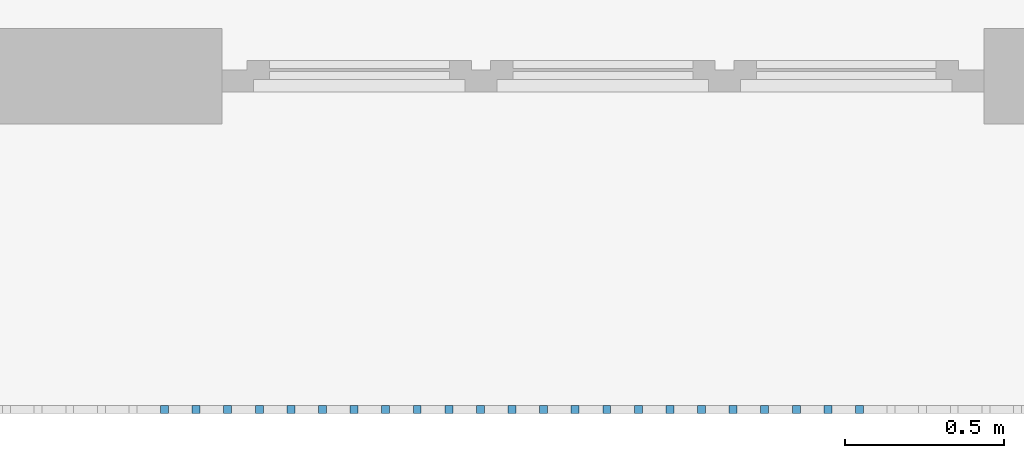
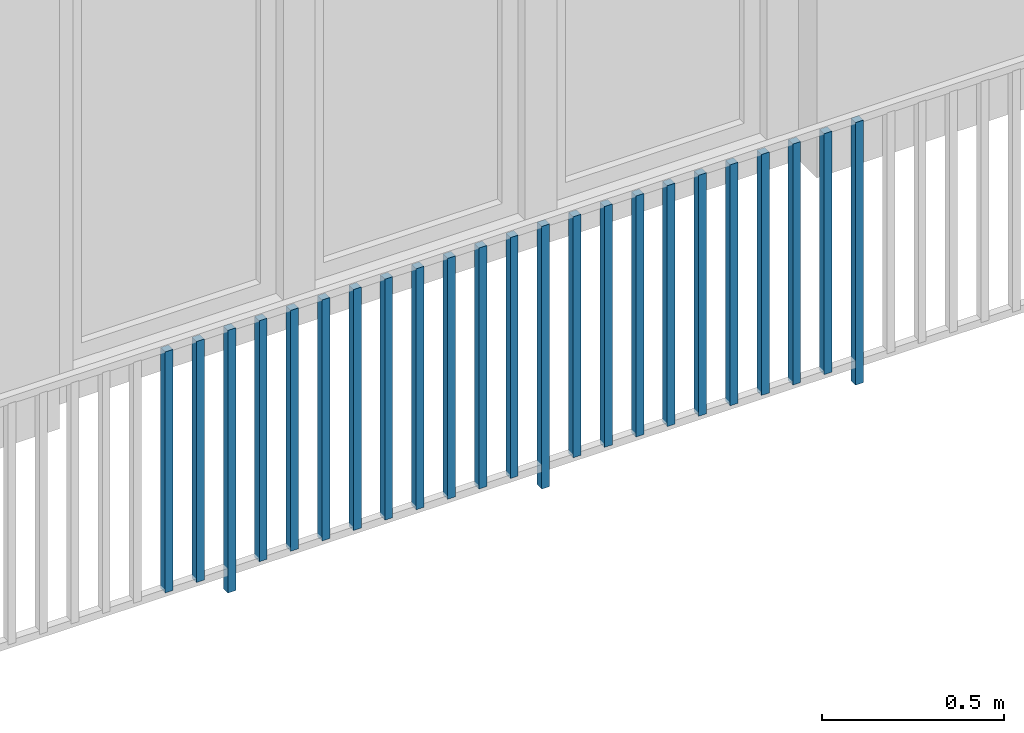
# One storey, part 34 of 54: 23 building element parts, 1 element without a shape of its own.
"""IFC4 building model written with IfcOpenShell, lengths in metres."""

from ifc_helpers import new_model, entity, si_unit, converted_unit, derived_unit, direction, frame, origin_with_axes, place, context, subcontext, project, spatial, polygons, material, type_object, element, aggregate, save


model = new_model("IFC4")

# Units and contexts
model_context = context("Model", 3, precision=1e-05, world=origin_with_axes(), true_north=direction((0.0, 1.0)))
body_context = subcontext(model_context, "Body", "Model", "MODEL_VIEW")
ifc_project = project(units=[si_unit("LENGTHUNIT", "METRE"), si_unit("AREAUNIT", "SQUARE_METRE"), si_unit("VOLUMEUNIT", "CUBIC_METRE"), converted_unit("PLANEANGLEUNIT", "DEGREE", entity("IfcPlaneAngleMeasure", 0.0174532925199), si_unit("PLANEANGLEUNIT", "RADIAN"), dimensions=[0, 0, 0, 0, 0, 0, 0]), converted_unit("TIMEUNIT", "Year", entity("IfcTimeMeasure", 31556926.0), si_unit("TIMEUNIT", "SECOND"), dimensions=[0, 0, 1, 0, 0, 0, 0]), si_unit("MASSUNIT", "GRAM", prefix="KILO"), si_unit("THERMODYNAMICTEMPERATUREUNIT", "DEGREE_CELSIUS"), si_unit("LUMINOUSINTENSITYUNIT", "LUMEN"), si_unit("ENERGYUNIT", "JOULE", prefix="MEGA"), derived_unit("THERMALCONDUCTANCEUNIT", [(si_unit("POWERUNIT", "WATT"), 1), (si_unit("LENGTHUNIT", "METRE"), -1), (si_unit("THERMODYNAMICTEMPERATUREUNIT", "KELVIN"), -1)]), derived_unit("SPECIFICHEATCAPACITYUNIT", [(si_unit("ENERGYUNIT", "JOULE"), 1), (si_unit("MASSUNIT", "GRAM", prefix="KILO"), -1), (si_unit("THERMODYNAMICTEMPERATUREUNIT", "KELVIN"), -1)]), derived_unit("MASSDENSITYUNIT", [(si_unit("MASSUNIT", "GRAM", prefix="KILO"), 1), (si_unit("VOLUMEUNIT", "CUBIC_METRE"), -1)])], contexts=[model_context])

# Site, building, storey, space
site_placement = place(None, origin_with_axes())
site = spatial("IfcSite", under=ifc_project, at=site_placement, CompositionType="ELEMENT")
building_placement = place(site_placement, origin_with_axes())
building = spatial("IfcBuilding", under=site, at=building_placement, CompositionType="ELEMENT")
storey_placement = place(building_placement, frame((0.0, 0.0, 9.18), z_axis=(0.0, 0.0, 1.0), x_axis=(1.0, 0.0, 0.0)))
storey = spatial("IfcBuildingStorey", under=building, at=storey_placement, Name="3. Geschoss", CompositionType="ELEMENT", Elevation=9.18)
space_placement = place(storey_placement, frame((10.2378006196, 9.82118769833, 0.0), z_axis=(0.0, 0.0, 1.0), x_axis=(-1.0, 0.0, 0.0)))
space = spatial("IfcSpace", under=storey, at=space_placement, CompositionType="ELEMENT", PredefinedType="EXTERNAL")

# Railing, building element parts
railing_type = type_object("IfcRailingType", PredefinedType="NOTDEFINED")
railing_placement = place(space_placement, frame((0.0, -7.06315681498e-08, 0.0), z_axis=(0.0, 0.0, 1.0), x_axis=(-1.0, 0.0, 0.0)))
railing = element("IfcRailing", 1, at=railing_placement, inside=space, type_object=railing_type, PredefinedType="NOTDEFINED")
ifc_material = material()
building_element_part_1_placement = place(railing_placement, origin_with_axes())
building_element_part_1 = element("IfcBuildingElementPart", 2, at=building_element_part_1_placement, material=ifc_material, PredefinedType="NOTDEFINED", context=body_context, shape_type="Tessellation", body=[
    polygons([(-17.0977608696, -20.6625, 0.07), (-17.0977608696, -20.6375, 0.07), (-17.0977608696, -20.6375, 0.8775), (-17.0977608696, -20.6625, 0.8775), (-17.1227608696, -20.6625, 0.07), (-17.1227608696, -20.6375, 0.07), (-17.1227608696, -20.6375, 0.8775), (-17.1227608696, -20.6625, 0.8775)], [[[1, 2, 3, 4]], [[1, 5, 6, 2]], [[2, 6, 7, 3]], [[4, 3, 7, 8]], [[5, 1, 4, 8]], [[6, 5, 8, 7]]], closed=True),
])
building_element_part_2_placement = place(railing_placement, origin_with_axes())
building_element_part_2 = element("IfcBuildingElementPart", 3, at=building_element_part_2_placement, material=ifc_material, PredefinedType="NOTDEFINED", context=body_context, shape_type="Tessellation", body=[
    polygons([(-16.9982826087, -20.6625, 0.07), (-16.9982826087, -20.6375, 0.07), (-16.9982826087, -20.6375, 0.8775), (-16.9982826087, -20.6625, 0.8775), (-17.0232826087, -20.6625, 0.07), (-17.0232826087, -20.6375, 0.07), (-17.0232826087, -20.6375, 0.8775), (-17.0232826087, -20.6625, 0.8775)], [[[1, 2, 3, 4]], [[1, 5, 6, 2]], [[2, 6, 7, 3]], [[4, 3, 7, 8]], [[5, 1, 4, 8]], [[6, 5, 8, 7]]], closed=True),
])
building_element_part_3_placement = place(railing_placement, origin_with_axes())
building_element_part_3 = element("IfcBuildingElementPart", 4, at=building_element_part_3_placement, material=ifc_material, PredefinedType="NOTDEFINED", context=body_context, shape_type="Tessellation", body=[
    polygons([(-16.8988043478, -20.6625, 0.0), (-16.8988043478, -20.6375, 0.0), (-16.8988043478, -20.6375, 0.88), (-16.8988043478, -20.6625, 0.88), (-16.9238043478, -20.6625, 0.0), (-16.9238043478, -20.6375, 0.0), (-16.9238043478, -20.6375, 0.88), (-16.9238043478, -20.6625, 0.88)], [[[1, 2, 3, 4]], [[1, 5, 6, 2]], [[2, 6, 7, 3]], [[4, 3, 7, 8]], [[5, 1, 4, 8]], [[6, 5, 8, 7]]], closed=True),
])
building_element_part_4_placement = place(railing_placement, origin_with_axes())
building_element_part_4 = element("IfcBuildingElementPart", 5, at=building_element_part_4_placement, material=ifc_material, PredefinedType="NOTDEFINED", context=body_context, shape_type="Tessellation", body=[
    polygons([(-16.799326087, -20.6625, 0.07), (-16.799326087, -20.6375, 0.07), (-16.799326087, -20.6375, 0.8775), (-16.799326087, -20.6625, 0.8775), (-16.824326087, -20.6625, 0.07), (-16.824326087, -20.6375, 0.07), (-16.824326087, -20.6375, 0.8775), (-16.824326087, -20.6625, 0.8775)], [[[1, 2, 3, 4]], [[1, 5, 6, 2]], [[2, 6, 7, 3]], [[4, 3, 7, 8]], [[5, 1, 4, 8]], [[6, 5, 8, 7]]], closed=True),
])
building_element_part_5_placement = place(railing_placement, origin_with_axes())
building_element_part_5 = element("IfcBuildingElementPart", 6, at=building_element_part_5_placement, material=ifc_material, PredefinedType="NOTDEFINED", context=body_context, shape_type="Tessellation", body=[
    polygons([(-16.6998478261, -20.6625, 0.07), (-16.6998478261, -20.6375, 0.07), (-16.6998478261, -20.6375, 0.8775), (-16.6998478261, -20.6625, 0.8775), (-16.7248478261, -20.6625, 0.07), (-16.7248478261, -20.6375, 0.07), (-16.7248478261, -20.6375, 0.8775), (-16.7248478261, -20.6625, 0.8775)], [[[1, 2, 3, 4]], [[1, 5, 6, 2]], [[2, 6, 7, 3]], [[4, 3, 7, 8]], [[5, 1, 4, 8]], [[6, 5, 8, 7]]], closed=True),
])
building_element_part_6_placement = place(railing_placement, origin_with_axes())
building_element_part_6 = element("IfcBuildingElementPart", 7, at=building_element_part_6_placement, material=ifc_material, PredefinedType="NOTDEFINED", context=body_context, shape_type="Tessellation", body=[
    polygons([(-16.6003695652, -20.6625, 0.07), (-16.6003695652, -20.6375, 0.07), (-16.6003695652, -20.6375, 0.8775), (-16.6003695652, -20.6625, 0.8775), (-16.6253695652, -20.6625, 0.07), (-16.6253695652, -20.6375, 0.07), (-16.6253695652, -20.6375, 0.8775), (-16.6253695652, -20.6625, 0.8775)], [[[1, 2, 3, 4]], [[1, 5, 6, 2]], [[2, 6, 7, 3]], [[4, 3, 7, 8]], [[5, 1, 4, 8]], [[6, 5, 8, 7]]], closed=True),
])
building_element_part_7_placement = place(railing_placement, origin_with_axes())
building_element_part_7 = element("IfcBuildingElementPart", 8, at=building_element_part_7_placement, material=ifc_material, PredefinedType="NOTDEFINED", context=body_context, shape_type="Tessellation", body=[
    polygons([(-16.5008913043, -20.6625, 0.07), (-16.5008913043, -20.6375, 0.07), (-16.5008913043, -20.6375, 0.8775), (-16.5008913043, -20.6625, 0.8775), (-16.5258913043, -20.6625, 0.07), (-16.5258913043, -20.6375, 0.07), (-16.5258913043, -20.6375, 0.8775), (-16.5258913043, -20.6625, 0.8775)], [[[1, 2, 3, 4]], [[1, 5, 6, 2]], [[2, 6, 7, 3]], [[4, 3, 7, 8]], [[5, 1, 4, 8]], [[6, 5, 8, 7]]], closed=True),
])
building_element_part_8_placement = place(railing_placement, origin_with_axes())
building_element_part_8 = element("IfcBuildingElementPart", 9, at=building_element_part_8_placement, material=ifc_material, PredefinedType="NOTDEFINED", context=body_context, shape_type="Tessellation", body=[
    polygons([(-16.4014130435, -20.6625, 0.07), (-16.4014130435, -20.6375, 0.07), (-16.4014130435, -20.6375, 0.8775), (-16.4014130435, -20.6625, 0.8775), (-16.4264130435, -20.6625, 0.07), (-16.4264130435, -20.6375, 0.07), (-16.4264130435, -20.6375, 0.8775), (-16.4264130435, -20.6625, 0.8775)], [[[1, 2, 3, 4]], [[1, 5, 6, 2]], [[2, 6, 7, 3]], [[4, 3, 7, 8]], [[5, 1, 4, 8]], [[6, 5, 8, 7]]], closed=True),
])
building_element_part_9_placement = place(railing_placement, origin_with_axes())
building_element_part_9 = element("IfcBuildingElementPart", 10, at=building_element_part_9_placement, material=ifc_material, PredefinedType="NOTDEFINED", context=body_context, shape_type="Tessellation", body=[
    polygons([(-16.3019347826, -20.6625, 0.07), (-16.3019347826, -20.6375, 0.07), (-16.3019347826, -20.6375, 0.8775), (-16.3019347826, -20.6625, 0.8775), (-16.3269347826, -20.6625, 0.07), (-16.3269347826, -20.6375, 0.07), (-16.3269347826, -20.6375, 0.8775), (-16.3269347826, -20.6625, 0.8775)], [[[1, 2, 3, 4]], [[1, 5, 6, 2]], [[2, 6, 7, 3]], [[4, 3, 7, 8]], [[5, 1, 4, 8]], [[6, 5, 8, 7]]], closed=True),
])
building_element_part_10_placement = place(railing_placement, origin_with_axes())
building_element_part_10 = element("IfcBuildingElementPart", 11, at=building_element_part_10_placement, material=ifc_material, PredefinedType="NOTDEFINED", context=body_context, shape_type="Tessellation", body=[
    polygons([(-16.2024565217, -20.6625, 0.07), (-16.2024565217, -20.6375, 0.07), (-16.2024565217, -20.6375, 0.8775), (-16.2024565217, -20.6625, 0.8775), (-16.2274565217, -20.6625, 0.07), (-16.2274565217, -20.6375, 0.07), (-16.2274565217, -20.6375, 0.8775), (-16.2274565217, -20.6625, 0.8775)], [[[1, 2, 3, 4]], [[1, 5, 6, 2]], [[2, 6, 7, 3]], [[4, 3, 7, 8]], [[5, 1, 4, 8]], [[6, 5, 8, 7]]], closed=True),
])
building_element_part_11_placement = place(railing_placement, origin_with_axes())
building_element_part_11 = element("IfcBuildingElementPart", 12, at=building_element_part_11_placement, material=ifc_material, PredefinedType="NOTDEFINED", context=body_context, shape_type="Tessellation", body=[
    polygons([(-16.1029782609, -20.6625, 0.07), (-16.1029782609, -20.6375, 0.07), (-16.1029782609, -20.6375, 0.8775), (-16.1029782609, -20.6625, 0.8775), (-16.1279782609, -20.6625, 0.07), (-16.1279782609, -20.6375, 0.07), (-16.1279782609, -20.6375, 0.8775), (-16.1279782609, -20.6625, 0.8775)], [[[1, 2, 3, 4]], [[1, 5, 6, 2]], [[2, 6, 7, 3]], [[4, 3, 7, 8]], [[5, 1, 4, 8]], [[6, 5, 8, 7]]], closed=True),
])
building_element_part_12_placement = place(railing_placement, origin_with_axes())
building_element_part_12 = element("IfcBuildingElementPart", 13, at=building_element_part_12_placement, material=ifc_material, PredefinedType="NOTDEFINED", context=body_context, shape_type="Tessellation", body=[
    polygons([(-16.0035, -20.6625, 0.07), (-16.0035, -20.6375, 0.07), (-16.0035, -20.6375, 0.8775), (-16.0035, -20.6625, 0.8775), (-16.0285, -20.6625, 0.07), (-16.0285, -20.6375, 0.07), (-16.0285, -20.6375, 0.8775), (-16.0285, -20.6625, 0.8775)], [[[1, 2, 3, 4]], [[1, 5, 6, 2]], [[2, 6, 7, 3]], [[4, 3, 7, 8]], [[5, 1, 4, 8]], [[6, 5, 8, 7]]], closed=True),
])
building_element_part_13_placement = place(railing_placement, origin_with_axes())
building_element_part_13 = element("IfcBuildingElementPart", 14, at=building_element_part_13_placement, material=ifc_material, PredefinedType="NOTDEFINED", context=body_context, shape_type="Tessellation", body=[
    polygons([(-15.9040217391, -20.6625, 0.0), (-15.9040217391, -20.6375, 0.0), (-15.9040217391, -20.6375, 0.88), (-15.9040217391, -20.6625, 0.88), (-15.9290217391, -20.6625, 0.0), (-15.9290217391, -20.6375, 0.0), (-15.9290217391, -20.6375, 0.88), (-15.9290217391, -20.6625, 0.88)], [[[1, 2, 3, 4]], [[1, 5, 6, 2]], [[2, 6, 7, 3]], [[4, 3, 7, 8]], [[5, 1, 4, 8]], [[6, 5, 8, 7]]], closed=True),
])
building_element_part_14_placement = place(railing_placement, origin_with_axes())
building_element_part_14 = element("IfcBuildingElementPart", 15, at=building_element_part_14_placement, material=ifc_material, PredefinedType="NOTDEFINED", context=body_context, shape_type="Tessellation", body=[
    polygons([(-15.8045434783, -20.6625, 0.07), (-15.8045434783, -20.6375, 0.07), (-15.8045434783, -20.6375, 0.8775), (-15.8045434783, -20.6625, 0.8775), (-15.8295434783, -20.6625, 0.07), (-15.8295434783, -20.6375, 0.07), (-15.8295434783, -20.6375, 0.8775), (-15.8295434783, -20.6625, 0.8775)], [[[1, 2, 3, 4]], [[1, 5, 6, 2]], [[2, 6, 7, 3]], [[4, 3, 7, 8]], [[5, 1, 4, 8]], [[6, 5, 8, 7]]], closed=True),
])
building_element_part_15_placement = place(railing_placement, origin_with_axes())
building_element_part_15 = element("IfcBuildingElementPart", 16, at=building_element_part_15_placement, material=ifc_material, PredefinedType="NOTDEFINED", context=body_context, shape_type="Tessellation", body=[
    polygons([(-15.7050652174, -20.6625, 0.07), (-15.7050652174, -20.6375, 0.07), (-15.7050652174, -20.6375, 0.8775), (-15.7050652174, -20.6625, 0.8775), (-15.7300652174, -20.6625, 0.07), (-15.7300652174, -20.6375, 0.07), (-15.7300652174, -20.6375, 0.8775), (-15.7300652174, -20.6625, 0.8775)], [[[1, 2, 3, 4]], [[1, 5, 6, 2]], [[2, 6, 7, 3]], [[4, 3, 7, 8]], [[5, 1, 4, 8]], [[6, 5, 8, 7]]], closed=True),
])
building_element_part_16_placement = place(railing_placement, origin_with_axes())
building_element_part_16 = element("IfcBuildingElementPart", 17, at=building_element_part_16_placement, material=ifc_material, PredefinedType="NOTDEFINED", context=body_context, shape_type="Tessellation", body=[
    polygons([(-15.6055869565, -20.6625, 0.07), (-15.6055869565, -20.6375, 0.07), (-15.6055869565, -20.6375, 0.8775), (-15.6055869565, -20.6625, 0.8775), (-15.6305869565, -20.6625, 0.07), (-15.6305869565, -20.6375, 0.07), (-15.6305869565, -20.6375, 0.8775), (-15.6305869565, -20.6625, 0.8775)], [[[1, 2, 3, 4]], [[1, 5, 6, 2]], [[2, 6, 7, 3]], [[4, 3, 7, 8]], [[5, 1, 4, 8]], [[6, 5, 8, 7]]], closed=True),
])
building_element_part_17_placement = place(railing_placement, origin_with_axes())
building_element_part_17 = element("IfcBuildingElementPart", 18, at=building_element_part_17_placement, material=ifc_material, PredefinedType="NOTDEFINED", context=body_context, shape_type="Tessellation", body=[
    polygons([(-15.5061086957, -20.6625, 0.07), (-15.5061086957, -20.6375, 0.07), (-15.5061086957, -20.6375, 0.8775), (-15.5061086957, -20.6625, 0.8775), (-15.5311086957, -20.6625, 0.07), (-15.5311086957, -20.6375, 0.07), (-15.5311086957, -20.6375, 0.8775), (-15.5311086957, -20.6625, 0.8775)], [[[1, 2, 3, 4]], [[1, 5, 6, 2]], [[2, 6, 7, 3]], [[4, 3, 7, 8]], [[5, 1, 4, 8]], [[6, 5, 8, 7]]], closed=True),
])
building_element_part_18_placement = place(railing_placement, origin_with_axes())
building_element_part_18 = element("IfcBuildingElementPart", 19, at=building_element_part_18_placement, material=ifc_material, PredefinedType="NOTDEFINED", context=body_context, shape_type="Tessellation", body=[
    polygons([(-15.4066304348, -20.6625, 0.07), (-15.4066304348, -20.6375, 0.07), (-15.4066304348, -20.6375, 0.8775), (-15.4066304348, -20.6625, 0.8775), (-15.4316304348, -20.6625, 0.07), (-15.4316304348, -20.6375, 0.07), (-15.4316304348, -20.6375, 0.8775), (-15.4316304348, -20.6625, 0.8775)], [[[1, 2, 3, 4]], [[1, 5, 6, 2]], [[2, 6, 7, 3]], [[4, 3, 7, 8]], [[5, 1, 4, 8]], [[6, 5, 8, 7]]], closed=True),
])
building_element_part_19_placement = place(railing_placement, origin_with_axes())
building_element_part_19 = element("IfcBuildingElementPart", 20, at=building_element_part_19_placement, material=ifc_material, PredefinedType="NOTDEFINED", context=body_context, shape_type="Tessellation", body=[
    polygons([(-15.3071521739, -20.6625, 0.07), (-15.3071521739, -20.6375, 0.07), (-15.3071521739, -20.6375, 0.8775), (-15.3071521739, -20.6625, 0.8775), (-15.3321521739, -20.6625, 0.07), (-15.3321521739, -20.6375, 0.07), (-15.3321521739, -20.6375, 0.8775), (-15.3321521739, -20.6625, 0.8775)], [[[1, 2, 3, 4]], [[1, 5, 6, 2]], [[2, 6, 7, 3]], [[4, 3, 7, 8]], [[5, 1, 4, 8]], [[6, 5, 8, 7]]], closed=True),
])
building_element_part_20_placement = place(railing_placement, origin_with_axes())
building_element_part_20 = element("IfcBuildingElementPart", 21, at=building_element_part_20_placement, material=ifc_material, PredefinedType="NOTDEFINED", context=body_context, shape_type="Tessellation", body=[
    polygons([(-15.207673913, -20.6625, 0.07), (-15.207673913, -20.6375, 0.07), (-15.207673913, -20.6375, 0.8775), (-15.207673913, -20.6625, 0.8775), (-15.232673913, -20.6625, 0.07), (-15.232673913, -20.6375, 0.07), (-15.232673913, -20.6375, 0.8775), (-15.232673913, -20.6625, 0.8775)], [[[1, 2, 3, 4]], [[1, 5, 6, 2]], [[2, 6, 7, 3]], [[4, 3, 7, 8]], [[5, 1, 4, 8]], [[6, 5, 8, 7]]], closed=True),
])
building_element_part_21_placement = place(railing_placement, origin_with_axes())
building_element_part_21 = element("IfcBuildingElementPart", 22, at=building_element_part_21_placement, material=ifc_material, PredefinedType="NOTDEFINED", context=body_context, shape_type="Tessellation", body=[
    polygons([(-15.1081956522, -20.6625, 0.07), (-15.1081956522, -20.6375, 0.07), (-15.1081956522, -20.6375, 0.8775), (-15.1081956522, -20.6625, 0.8775), (-15.1331956522, -20.6625, 0.07), (-15.1331956522, -20.6375, 0.07), (-15.1331956522, -20.6375, 0.8775), (-15.1331956522, -20.6625, 0.8775)], [[[1, 2, 3, 4]], [[1, 5, 6, 2]], [[2, 6, 7, 3]], [[4, 3, 7, 8]], [[5, 1, 4, 8]], [[6, 5, 8, 7]]], closed=True),
])
building_element_part_22_placement = place(railing_placement, origin_with_axes())
building_element_part_22 = element("IfcBuildingElementPart", 23, at=building_element_part_22_placement, material=ifc_material, PredefinedType="NOTDEFINED", context=body_context, shape_type="Tessellation", body=[
    polygons([(-15.0087173913, -20.6625, 0.07), (-15.0087173913, -20.6375, 0.07), (-15.0087173913, -20.6375, 0.8775), (-15.0087173913, -20.6625, 0.8775), (-15.0337173913, -20.6625, 0.07), (-15.0337173913, -20.6375, 0.07), (-15.0337173913, -20.6375, 0.8775), (-15.0337173913, -20.6625, 0.8775)], [[[1, 2, 3, 4]], [[1, 5, 6, 2]], [[2, 6, 7, 3]], [[4, 3, 7, 8]], [[5, 1, 4, 8]], [[6, 5, 8, 7]]], closed=True),
])
building_element_part_23_placement = place(railing_placement, origin_with_axes())
building_element_part_23 = element("IfcBuildingElementPart", 24, at=building_element_part_23_placement, material=ifc_material, PredefinedType="NOTDEFINED", context=body_context, shape_type="Tessellation", body=[
    polygons([(-14.9092391304, -20.6625, 0.0), (-14.9092391304, -20.6375, 0.0), (-14.9092391304, -20.6375, 0.88), (-14.9092391304, -20.6625, 0.88), (-14.9342391304, -20.6625, 0.0), (-14.9342391304, -20.6375, 0.0), (-14.9342391304, -20.6375, 0.88), (-14.9342391304, -20.6625, 0.88)], [[[1, 2, 3, 4]], [[1, 5, 6, 2]], [[2, 6, 7, 3]], [[4, 3, 7, 8]], [[5, 1, 4, 8]], [[6, 5, 8, 7]]], closed=True),
])
aggregate(railing, [building_element_part_1, building_element_part_2, building_element_part_3, building_element_part_4, building_element_part_5, building_element_part_6, building_element_part_7, building_element_part_8, building_element_part_9, building_element_part_10, building_element_part_11, building_element_part_12, building_element_part_13, building_element_part_14, building_element_part_15, building_element_part_16, building_element_part_17, building_element_part_18, building_element_part_19, building_element_part_20, building_element_part_21, building_element_part_22, building_element_part_23])

save(model, "model.ifc")
